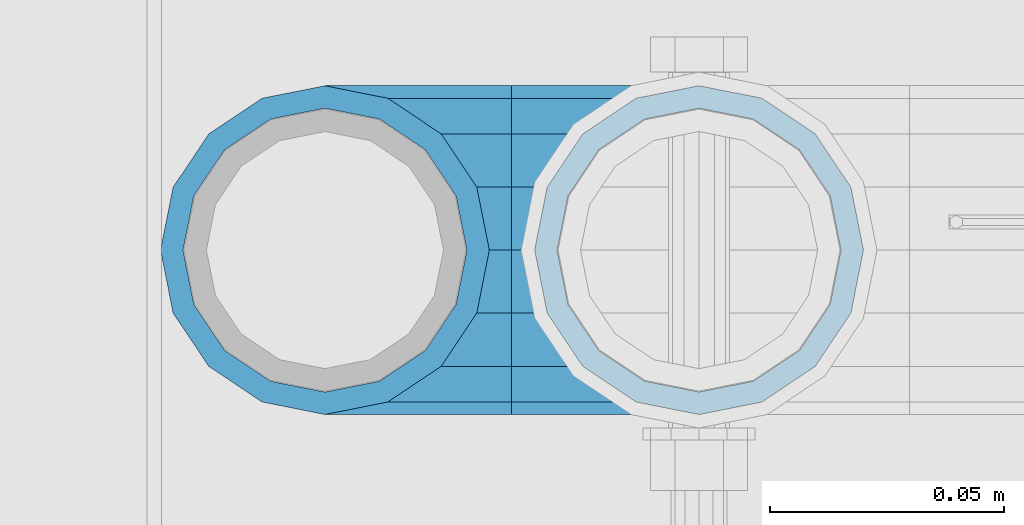
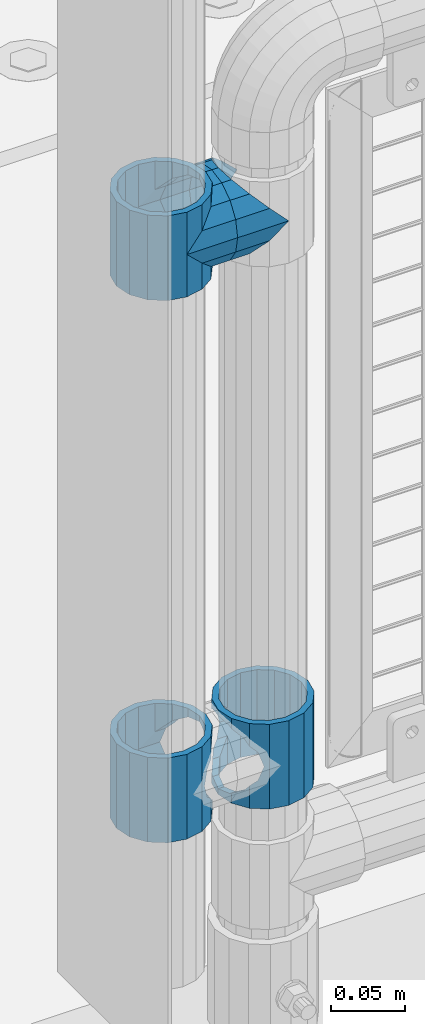
# One storey, part 146 of 257: 5 beams.
"""IFC2X3 building model written with IfcOpenShell, lengths in millimetres."""

import ifcopenshell
import ifcopenshell.guid

model = None  # the IFC model being written
_history = None  # IfcOwnerHistory: only IFC2X3 demands one
_inside = {}  # id of a spatial element -> (the spatial element, [elements in it])
_under = {}  # id of a project, library or spatial element -> (it, [spatial elements below it])
_declared = {}  # id of a project -> (the project, [libraries it declares])
_typed = {}  # id of a type object -> (the type object, [elements of that type])
_made_of = {}  # id of a material, layer set ... -> (it, [elements and type objects made of it])


def new_model(schema):
    """Start an empty IFC model of exactly this schema.

    Asked for "IFC4X3", IfcOpenShell would pick the latest addendum, in which some entities
    have other attributes; the version numbers below select the first issue.
    IFC2X3 requires an IfcOwnerHistory on every rooted entity: one is made here for all.
    """
    global model, _history
    if schema == "IFC4X3":
        model = ifcopenshell.file(schema_version=(4, 3, 0, 0))
    else:
        model = ifcopenshell.file(schema=schema)
    _inside.clear()
    _under.clear()
    _declared.clear()
    _typed.clear()
    _made_of.clear()
    _history = None
    if model.schema == "IFC2X3":
        org = make("IfcOrganization", Name="unknown")
        user = make(
            "IfcPersonAndOrganization",
            ThePerson=make("IfcPerson", FamilyName="unknown"),
            TheOrganization=org,
        )
        app = make(
            "IfcApplication",
            ApplicationDeveloper=org,
            Version="unknown",
            ApplicationFullName="unknown",
            ApplicationIdentifier="unknown",
        )
        _history = make(
            "IfcOwnerHistory",
            OwningUser=user,
            OwningApplication=app,
            ChangeAction="ADDED",
            CreationDate=0,
        )
    return model


def make(cls, **values):
    """One entity of the class cls with the attributes given. An attribute that is None is left unset."""
    return model.create_entity(
        cls, **{name: value for name, value in values.items() if value is not None}
    )


def rooted(cls, **values):
    """An entity with a GlobalId (a new one), such as an element, a storey or a relation."""
    return make(cls, GlobalId=ifcopenshell.guid.new(), OwnerHistory=_history, **values)


def si_unit(unit_type, name, prefix=None):
    """IfcSIUnit, for example si_unit("LENGTHUNIT", "METRE", prefix="MILLI")."""
    return make("IfcSIUnit", UnitType=unit_type, Prefix=prefix, Name=name)


def assignment(units):
    """IfcUnitAssignment: the units of a project."""
    return None if units is None else make("IfcUnitAssignment", Units=units)


def point(xyz):
    """IfcCartesianPoint."""
    return None if xyz is None else make("IfcCartesianPoint", Coordinates=xyz)


def direction(xyz):
    """IfcDirection."""
    return None if xyz is None else make("IfcDirection", DirectionRatios=xyz)


def frame(location, z_axis=None, x_axis=None):
    """IfcAxis2Placement3D, a coordinate frame: its origin and axes. An axis left out is left unset."""
    return make(
        "IfcAxis2Placement3D",
        Location=point(location),
        Axis=direction(z_axis),
        RefDirection=direction(x_axis),
    )


def origin_with_axes():
    """The frame at (0, 0, 0) with the z axis (0, 0, 1) and the x axis (1, 0, 0) written out."""
    return frame((0.0, 0.0, 0.0), z_axis=(0.0, 0.0, 1.0), x_axis=(1.0, 0.0, 0.0))


def place(relative_to, where):
    """IfcLocalPlacement: puts the frame where relative to a parent placement (None: the world)."""
    return make(
        "IfcLocalPlacement", PlacementRelTo=relative_to, RelativePlacement=where
    )


def context(
    kind, dimensions, precision=None, world=None, true_north=None, identifier=None
):
    """IfcGeometricRepresentationContext, for example the 3D "Model" context."""
    return make(
        "IfcGeometricRepresentationContext",
        ContextIdentifier=identifier,
        ContextType=kind,
        CoordinateSpaceDimension=dimensions,
        Precision=precision,
        WorldCoordinateSystem=world,
        TrueNorth=true_north,
    )


def subcontext(parent, identifier, kind, view, scale=None):
    """IfcGeometricRepresentationSubContext, for example "Body" below "Model"."""
    return make(
        "IfcGeometricRepresentationSubContext",
        ContextIdentifier=identifier,
        ContextType=kind,
        ParentContext=parent,
        TargetScale=scale,
        TargetView=view,
    )


def project(units=None, contexts=None):
    """IfcProject with its units and contexts."""
    return rooted(
        "IfcProject",
        Name="project",
        RepresentationContexts=contexts,
        UnitsInContext=assignment(units),
    )


def spatial(cls, under=None, at=None, **own):
    """A site, building, storey or space (cls), placed at a placement, below another one or the project."""
    s = rooted(cls, ObjectPlacement=at, **own)
    if under is not None:
        _under.setdefault(under.id(), (under, []))[1].append(s)
    return s


def faces_of(points, faces, orient=None, outer=None):
    """IfcFace entities. A face is a list of loops; a loop is a list of indices into points, from 0.

    orient and outer hold one flag for each loop. By default every Orientation is true, the
    first loop of a face is its IfcFaceOuterBound and the others are IfcFaceBound.
    """
    made = []
    for i, loops in enumerate(faces):
        bounds = []
        for j, loop in enumerate(loops):
            is_outer = j == 0 if outer is None else outer[i][j]
            bounds.append(
                make(
                    "IfcFaceOuterBound" if is_outer else "IfcFaceBound",
                    Bound=make("IfcPolyLoop", Polygon=[points[k] for k in loop]),
                    Orientation=True if orient is None else orient[i][j],
                )
            )
        made.append(make("IfcFace", Bounds=bounds))
    return made


def faceted_brep(points, faces, orient=None, outer=None, voids=None):
    """IfcFacetedBrep: a solid bounded by flat faces; with voids (closed shells), ...WithVoids."""
    shared = [point(p) for p in points]
    hull = make("IfcClosedShell", CfsFaces=faces_of(shared, faces, orient, outer))
    if voids is None:
        return make("IfcFacetedBrep", Outer=hull)
    return make(
        "IfcFacetedBrepWithVoids",
        Outer=hull,
        Voids=[
            make(cls, CfsFaces=faces_of(shared, fs, o, b)) for cls, fs, o, b in voids
        ],
    )


def shape(context_of_items, identifier, shape_type, items):
    """IfcShapeRepresentation: the items that make up one representation, for example the "Body"."""
    return make(
        "IfcShapeRepresentation",
        ContextOfItems=context_of_items,
        RepresentationIdentifier=identifier,
        RepresentationType=shape_type,
        Items=items,
    )


def material(Name=None, Category=None):
    """IfcMaterial."""
    return make("IfcMaterial", Name=Name, Category=Category)


def made_of(thing, what):
    """Note that an element or type object is made of a material, layer set ...; save() writes the relation."""
    if what is not None:
        _made_of.setdefault(what.id(), (what, []))[1].append(thing)
    return thing


def type_object(cls, material=None, **own):
    """A type object (cls), such as IfcWallType, which elements share."""
    return made_of(rooted(cls, **own), material)


def element(
    cls,
    number,
    at=None,
    inside=None,
    cuts=None,
    type_object=None,
    material=None,
    context=None,
    identifier="Body",
    shape_type=None,
    held_by="IfcProductDefinitionShape",
    body=None,
    shapes=None,
    **own,
):
    """One element of the class cls, such as IfcWall. Its Tag is "e" and its number.

    at: its placement. inside: the storey or other place that contains it. cuts: it is an
    opening in that element (IfcRelVoidsElement). A single representation is given by context,
    identifier, shape_type and body (its items); several are given by shapes. held_by: the class
    of the entity that holds the representations. save() writes the other relations.
    """
    e = rooted(cls, Tag="e%d" % number, ObjectPlacement=at, **own)
    if body is not None:
        shapes = [shape(context, identifier, shape_type, body)]
    if shapes is not None:
        e.Representation = make(held_by, Representations=shapes)
    if inside is not None:
        _inside.setdefault(inside.id(), (inside, []))[1].append(e)
    if cuts is not None:
        rooted(
            "IfcRelVoidsElement", RelatingBuildingElement=cuts, RelatedOpeningElement=e
        )
    if type_object is not None:
        _typed.setdefault(type_object.id(), (type_object, []))[1].append(e)
    return made_of(e, material)


def aggregate(whole, parts):
    """IfcRelAggregates: a whole, such as a stair, and the parts it consists of."""
    return rooted("IfcRelAggregates", RelatingObject=whole, RelatedObjects=parts)


def save(model, path):
    """Write the relations noted so far, then the file.

    IfcRelAggregates (storeys below a building ...), IfcRelContainedInSpatialStructure (elements
    in a storey), IfcRelDefinesByType, IfcRelAssociatesMaterial and IfcRelDeclares: one each for
    every whole, place, type object, material and project.
    """
    for whole, parts in _under.values():
        aggregate(whole, parts)
    for where, things in _inside.values():
        rooted(
            "IfcRelContainedInSpatialStructure",
            RelatedElements=things,
            RelatingStructure=where,
        )
    for kind, things in _typed.values():
        rooted("IfcRelDefinesByType", RelatedObjects=things, RelatingType=kind)
    for what, things in _made_of.values():
        rooted("IfcRelAssociatesMaterial", RelatedObjects=things, RelatingMaterial=what)
    for by, libraries in _declared.values():
        rooted("IfcRelDeclares", RelatingContext=by, RelatedDefinitions=libraries)
    model.write(path)


model = new_model("IFC2X3")

# Units and contexts
model_context = context("Model", 3, precision=1e-05, world=origin_with_axes())
body_context = subcontext(model_context, "Body", "Model", "MODEL_VIEW")
ifc_project = project(units=[si_unit("LENGTHUNIT", "METRE", prefix="MILLI"), si_unit("AREAUNIT", "SQUARE_METRE"), si_unit("VOLUMEUNIT", "CUBIC_METRE"), si_unit("MASSUNIT", "GRAM", prefix="KILO"), si_unit("TIMEUNIT", "SECOND"), si_unit("PLANEANGLEUNIT", "RADIAN"), si_unit("SOLIDANGLEUNIT", "STERADIAN"), si_unit("THERMODYNAMICTEMPERATUREUNIT", "DEGREE_CELSIUS"), si_unit("LUMINOUSINTENSITYUNIT", "LUMEN")], contexts=[model_context])

# Site, building, storey
site_placement = place(None, origin_with_axes())
site = spatial("IfcSite", under=ifc_project, at=site_placement, CompositionType="ELEMENT")
building_placement = place(site_placement, origin_with_axes())
building = spatial("IfcBuilding", under=site, at=building_placement, Name="Standard", CompositionType="ELEMENT")
storey_placement = place(building_placement, origin_with_axes())
storey = spatial("IfcBuildingStorey", under=building, at=storey_placement, Name="Undefined", CompositionType="ELEMENT", Elevation=0.0)

# Beams
ifc_material = material(Name="Misc_Undefined")
beam_type = type_object("IfcBeamType", PredefinedType="NOTDEFINED")
beam_1_placement = place(storey_placement, frame((42991.0, 10664.5, 433.819999999999), z_axis=(-1.0, 0.0, 0.0), x_axis=(0.0, 0.0, -1.0)))
element("IfcBeam", 1, at=beam_1_placement, inside=storey, type_object=beam_type, material=ifc_material, context=body_context, shape_type="Brep", body=[
    faceted_brep([(7.11025618828205, -11.6144421722802, -32.8397438117245), (7.11025618828205, -11.6144421722802, -28.0397438117143), (13.6893091909879, -21.4606908090118, -21.4606908090136), (13.6893091909879, -21.4606908090118, -27.1226768591077), (8.33762048232484, -13.4513226476338, -32.4743655677739), (23.5355578277191, -28.0397438117179, -11.6144421722784), (23.5355578277191, -28.0397438117179, -20.0882031229849), (18.7689575919987, -24.8548033587067, -24.8548033587067), (35.1500000000015, -30.35, 0.0), (35.1499999999996, -30.3500000000004, -16.6306603983685), (46.7644421722801, -28.0397438117179, -11.6144421722784), (46.7644421722801, -28.0397438117179, -20.0882031229849), (51.5310424080038, -24.8548033587067, -24.8548033587067), (56.6106908090114, -21.4606908090118, -21.4606908090136), (56.6106908090114, -21.4606908090118, -27.1226768591077), (61.9623795176756, -13.4513226476338, -32.4743655677739), (63.1897438117172, -11.6144421722802, -28.0397438117143), (63.1897438117172, -11.6144421722802, -32.8397438117245), (65.4999999999997, 0.0, -30.3499999999985), (65.4999999999997, 0.0, -35.1500000000015), (63.1897438117172, 11.6144421722802, -28.0397438117143), (63.1897438117172, 11.6144421722802, -32.8397438117245), (56.6106908090114, 21.4606908090118, -21.4606908090136), (56.6106908090114, 21.4606908090118, -27.1226768591077), (61.9623795176756, 13.4513226476338, -32.4743655677739), (46.7644421722801, 28.0397438117179, -11.6144421722784), (46.7644421722801, 28.0397438117179, -20.0882031229921), (51.5310424080039, 24.8548033587067, -24.8548033587067), (35.1500000000015, 30.35, 0.0), (35.1499999999996, 30.3500000000004, -16.6306603983758), (23.5355578277192, 28.0397438117179, -11.6144421722784), (23.5355578277192, 28.0397438117179, -20.0882031229921), (18.7689575919954, 24.8548033587067, -24.8548033587067), (13.6893091909879, 21.4606908090118, -21.4606908090136), (13.6893091909879, 21.4606908090118, -27.1226768591077), (8.3376204823237, 13.4513226476338, -32.4743655677739), (7.11025618828211, 11.6144421722802, -28.0397438117143), (7.11025618828211, 11.6144421722802, -32.8397438117245), (4.79999999999961, 0.0, -30.3499999999985), (4.79999999999961, 0.0, -35.1500000000015), (0.0, 21.4606908090118, 21.4606908090136), (0.0, 28.0397438117179, 11.6144421722784), (70.2999999999993, 28.0397438117179, 11.6144421722784), (70.2999999999993, 21.4606908090118, 21.4606908090136), (0.0, 11.6144421722802, 28.0397438117143), (70.2999999999993, 11.6144421722802, 28.0397438117143), (0.0, 0.0, 30.3499999999985), (70.2999999999993, 0.0, 30.3499999999985), (0.0, -11.6144421722802, 28.0397438117143), (70.2999999999993, -11.6144421722802, 28.0397438117143), (0.0, -21.4606908090118, 21.4606908090136), (70.2999999999993, -21.4606908090118, 21.4606908090136), (0.0, -28.0397438117179, 11.6144421722784), (70.2999999999993, -28.0397438117179, 11.6144421722784), (0.0, -24.8548033587067, -24.8548033587067), (0.0, -13.4513226476338, -32.4743655677739), (0.0, 0.0, -35.1499999999996), (0.0, -32.4743655677721, 13.4513226476338), (0.0, -35.1499999999996, 0.0), (70.2999999999993, -35.1499999999996, 0.0), (70.2999999999993, -32.4743655677721, 13.4513226476338), (0.0, -24.8548033587067, 24.8548033587067), (70.2999999999993, -24.8548033587067, 24.8548033587067), (0.0, -13.4513226476338, 32.4743655677739), (70.2999999999993, -13.4513226476338, 32.4743655677739), (0.0, 0.0, 35.1499999999996), (70.2999999999993, 0.0, 35.1500000000015), (0.0, 13.4513226476338, 32.4743655677739), (70.2999999999993, 13.4513226476338, 32.4743655677739), (0.0, 24.8548033587067, 24.8548033587067), (70.2999999999993, 24.8548033587067, 24.8548033587067), (0.0, 32.4743655677721, 13.4513226476338), (70.2999999999993, 32.4743655677721, 13.4513226476338), (0.0, 35.1499999999996, 0.0), (70.2999999999993, 35.1499999999996, 0.0), (0.0, 32.4743655677721, -13.4513226476338), (70.2999999999993, 32.4743655677721, -13.4513226476338), (70.2999999999993, -13.4513226476338, -32.4743655677739), (70.2999999999993, -24.8548033587067, -24.8548033587067), (70.2999999999993, 0.0, -35.1500000000015), (70.2999999999993, 13.4513226476338, -32.4743655677739), (70.2999999999993, 24.8548033587067, -24.8548033587067), (0.0, 24.8548033587067, -24.8548033587067), (0.0, 13.4513226476338, -32.4743655677739), (70.2999999999993, -32.4743655677721, -13.4513226476338), (0.0, -32.4743655677721, -13.4513226476338), (0.0, -28.0397438117179, -11.6144421722784), (0.0, -21.4606908090118, -21.4606908090136), (0.0, -11.6144421722802, -28.0397438117143), (0.0, 0.0, -30.3499999999985), (0.0, 11.6144421722802, -28.0397438117143), (0.0, 21.4606908090118, -21.4606908090136), (0.0, 28.0397438117179, -11.6144421722784), (0.0, 30.3500000000004, 0.0), (0.0, -30.3500000000004, 0.0), (70.2999999999993, 30.3500000000004, 0.0), (70.2999999999993, 28.0397438117179, -11.6144421722784), (70.2999999999993, 21.4606908090118, -21.4606908090136), (70.2999999999993, 11.6144421722802, -28.0397438117143), (70.2999999999993, 0.0, -30.3499999999985), (70.2999999999993, -11.6144421722802, -28.0397438117143), (70.2999999999993, -21.4606908090118, -21.4606908090136), (70.2999999999993, -28.0397438117179, -11.6144421722784), (70.2999999999993, -30.3500000000004, 0.0)], [[[0, 1, 2, 3, 4]], [[3, 2, 5, 6, 7]], [[6, 5, 8, 9]], [[9, 8, 10, 11]], [[12, 11, 10, 13, 14]], [[15, 14, 13, 16, 17]], [[17, 16, 18, 19]], [[19, 18, 20, 21]], [[21, 20, 22, 23, 24]], [[23, 22, 25, 26, 27]], [[26, 25, 28, 29]], [[29, 28, 30, 31]], [[32, 31, 30, 33, 34]], [[35, 34, 33, 36, 37]], [[37, 36, 38, 39]], [[39, 38, 1, 0]], [[40, 41, 42, 43]], [[44, 40, 43, 45]], [[46, 44, 45, 47]], [[48, 46, 47, 49]], [[50, 48, 49, 51]], [[52, 50, 51, 53]], [[7, 54, 55, 4, 3]], [[4, 55, 56, 39, 0]], [[57, 58, 59, 60]], [[61, 57, 60, 62]], [[63, 61, 62, 64]], [[65, 63, 64, 66]], [[67, 65, 66, 68]], [[69, 67, 68, 70]], [[71, 69, 70, 72]], [[73, 71, 72, 74]], [[75, 73, 74, 76]], [[77, 78, 12, 14, 15]], [[79, 77, 15, 17, 19]], [[24, 80, 79, 19, 21]], [[27, 81, 80, 24, 23]], [[29, 31, 32, 82, 75, 76, 81, 27, 26]], [[83, 82, 32, 34, 35]], [[56, 83, 35, 37, 39]], [[78, 84, 85, 54, 7, 6, 9, 11, 12]], [[58, 85, 84, 59]], [[57, 61, 63, 65, 67, 69, 71, 73, 75, 82, 83, 56, 55, 54, 85, 58], [86, 87, 88, 89, 90, 91, 92, 93, 41, 40, 44, 46, 48, 50, 52, 94]], [[90, 89, 38, 36]], [[91, 90, 36, 33]], [[92, 91, 33, 30]], [[93, 92, 30, 28]], [[41, 93, 28, 95, 42]], [[96, 95, 28, 25]], [[97, 96, 25, 22]], [[98, 97, 22, 20]], [[99, 98, 20, 18]], [[100, 99, 18, 16]], [[101, 100, 16, 13]], [[102, 101, 13, 10]], [[103, 102, 10, 8]], [[78, 77, 79, 80, 81, 76, 74, 72, 70, 68, 66, 64, 62, 60, 59, 84], [51, 49, 47, 45, 43, 42, 95, 96, 97, 98, 99, 100, 101, 102, 103, 53]], [[8, 94, 52, 53, 103]], [[86, 94, 8, 5]], [[87, 86, 5, 2]], [[88, 87, 2, 1]], [[89, 88, 1, 38]]]),
])
beam_2_placement = place(storey_placement, frame((43071.0, 10664.5, 433.819999999999), z_axis=(1.0, 0.0, 0.0), x_axis=(0.0, 0.0, -1.0)))
element("IfcBeam", 2, at=beam_2_placement, inside=storey, type_object=beam_type, material=ifc_material, context=body_context, shape_type="Brep", body=[
    faceted_brep([(56.6106908090114, 21.4606908090118, -27.1226768591077), (56.6106908090114, 21.4606908090118, -21.4606908090136), (46.7644421722801, 28.0397438117179, -11.6144421722784), (46.7644421722801, 28.0397438117179, -20.0882031229921), (51.5310424080039, 24.8548033587067, -24.8548033587067), (63.1897438117172, 11.6144421722802, -32.8397438117245), (63.1897438117172, 11.6144421722802, -28.0397438117143), (61.9623795176756, 13.4513226476338, -32.4743655677739), (65.4999999999997, 0.0, -35.1500000000015), (65.4999999999997, 0.0, -30.3499999999985), (63.1897438117172, -11.6144421722802, -32.8397438117245), (63.1897438117172, -11.6144421722802, -28.0397438117143), (61.9623795176756, -13.4513226476338, -32.4743655677739), (56.6106908090114, -21.4606908090118, -27.1226768591077), (56.6106908090114, -21.4606908090118, -21.4606908090136), (51.5310424080038, -24.8548033587067, -24.8548033587067), (46.7644421722801, -28.0397438117179, -20.0882031229849), (46.7644421722801, -28.0397438117179, -11.6144421722784), (35.1499999999996, -30.3500000000004, -16.6306603983685), (35.1500000000015, -30.35, 0.0), (23.5355578277191, -28.0397438117179, -20.0882031229849), (23.5355578277191, -28.0397438117179, -11.6144421722784), (13.6893091909879, -21.4606908090118, -27.1226768591077), (13.6893091909879, -21.4606908090118, -21.4606908090136), (18.7689575919987, -24.8548033587067, -24.8548033587067), (7.11025618828205, -11.6144421722802, -32.8397438117245), (7.11025618828205, -11.6144421722802, -28.0397438117143), (8.33762048232484, -13.4513226476338, -32.4743655677739), (4.79999999999961, 0.0, -35.1500000000015), (4.79999999999961, 0.0, -30.3499999999985), (7.11025618828211, 11.6144421722802, -32.8397438117245), (7.11025618828211, 11.6144421722802, -28.0397438117143), (8.3376204823237, 13.4513226476338, -32.4743655677739), (13.6893091909879, 21.4606908090118, -27.1226768591077), (13.6893091909879, 21.4606908090118, -21.4606908090136), (18.7689575919954, 24.8548033587067, -24.8548033587067), (23.5355578277192, 28.0397438117179, -20.0882031229921), (23.5355578277192, 28.0397438117179, -11.6144421722784), (35.1499999999996, 30.3500000000004, -16.6306603983758), (35.1500000000015, 30.35, 0.0), (0.0, 32.4743655677721, -13.4513226476338), (0.0, 35.1499999999996, 0.0), (70.2999999999993, 35.1499999999996, 0.0), (70.2999999999993, 32.4743655677721, -13.4513226476338), (0.0, 32.4743655677721, 13.4513226476338), (70.2999999999993, 32.4743655677721, 13.4513226476338), (0.0, 24.8548033587067, 24.8548033587067), (70.2999999999993, 24.8548033587067, 24.8548033587067), (0.0, 13.4513226476338, 32.4743655677739), (70.2999999999993, 13.4513226476338, 32.4743655677739), (0.0, 0.0, 35.1499999999996), (70.2999999999993, 0.0, 35.1500000000015), (0.0, -13.4513226476338, 32.4743655677739), (70.2999999999993, -13.4513226476338, 32.4743655677739), (0.0, -24.8548033587067, 24.8548033587067), (70.2999999999993, -24.8548033587067, 24.8548033587067), (0.0, -32.4743655677721, 13.4513226476338), (70.2999999999993, -32.4743655677721, 13.4513226476338), (0.0, -35.1499999999996, 0.0), (70.2999999999993, -35.1499999999996, 0.0), (70.2999999999993, -30.3500000000004, 0.0), (70.2999999999993, -28.0397438117179, -11.6144421722784), (70.2999999999993, -21.4606908090118, -21.4606908090136), (70.2999999999993, -11.6144421722802, -28.0397438117143), (70.2999999999993, 0.0, -30.3499999999985), (70.2999999999993, 11.6144421722802, -28.0397438117143), (70.2999999999993, 21.4606908090118, -21.4606908090136), (70.2999999999993, 28.0397438117179, -11.6144421722784), (0.0, -28.0397438117179, -11.6144421722784), (0.0, -30.3500000000004, 0.0), (0.0, -21.4606908090118, -21.4606908090136), (0.0, -11.6144421722802, -28.0397438117143), (0.0, 0.0, -30.3499999999985), (0.0, 11.6144421722802, -28.0397438117143), (0.0, 21.4606908090118, -21.4606908090136), (0.0, 28.0397438117179, -11.6144421722784), (0.0, 30.3500000000004, 0.0), (70.2999999999993, 30.3500000000004, 0.0), (0.0, 28.0397438117179, 11.6144421722784), (70.2999999999993, 28.0397438117179, 11.6144421722784), (0.0, 21.4606908090118, 21.4606908090136), (70.2999999999993, 21.4606908090118, 21.4606908090136), (0.0, 11.6144421722802, 28.0397438117143), (70.2999999999993, 11.6144421722802, 28.0397438117143), (0.0, 0.0, 30.3499999999985), (70.2999999999993, 0.0, 30.3499999999985), (0.0, -11.6144421722802, 28.0397438117143), (70.2999999999993, -11.6144421722802, 28.0397438117143), (0.0, -21.4606908090118, 21.4606908090136), (70.2999999999993, -21.4606908090118, 21.4606908090136), (0.0, -28.0397438117179, 11.6144421722784), (70.2999999999993, -28.0397438117179, 11.6144421722784), (70.2999999999993, -24.8548033587067, -24.8548033587067), (70.2999999999993, -13.4513226476338, -32.4743655677739), (70.2999999999993, 0.0, -35.1500000000015), (70.2999999999993, 13.4513226476338, -32.4743655677739), (70.2999999999993, 24.8548033587067, -24.8548033587067), (70.2999999999993, -32.4743655677721, -13.4513226476338), (0.0, -32.4743655677721, -13.4513226476338), (0.0, 24.8548033587067, -24.8548033587067), (0.0, 13.4513226476338, -32.4743655677739), (0.0, 0.0, -35.1499999999996), (0.0, -13.4513226476338, -32.4743655677739), (0.0, -24.8548033587067, -24.8548033587067)], [[[0, 1, 2, 3, 4]], [[5, 6, 1, 0, 7]], [[8, 9, 6, 5]], [[10, 11, 9, 8]], [[12, 13, 14, 11, 10]], [[15, 16, 17, 14, 13]], [[18, 19, 17, 16]], [[20, 21, 19, 18]], [[22, 23, 21, 20, 24]], [[25, 26, 23, 22, 27]], [[28, 29, 26, 25]], [[30, 31, 29, 28]], [[32, 33, 34, 31, 30]], [[35, 36, 37, 34, 33]], [[38, 39, 37, 36]], [[3, 2, 39, 38]], [[40, 41, 42, 43]], [[41, 44, 45, 42]], [[44, 46, 47, 45]], [[46, 48, 49, 47]], [[48, 50, 51, 49]], [[50, 52, 53, 51]], [[52, 54, 55, 53]], [[54, 56, 57, 55]], [[56, 58, 59, 57]], [[60, 61, 17, 19]], [[61, 62, 14, 17]], [[62, 63, 11, 14]], [[63, 64, 9, 11]], [[64, 65, 6, 9]], [[65, 66, 1, 6]], [[66, 67, 2, 1]], [[68, 69, 19, 21]], [[70, 68, 21, 23]], [[71, 70, 23, 26]], [[72, 71, 26, 29]], [[73, 72, 29, 31]], [[74, 73, 31, 34]], [[75, 74, 34, 37]], [[76, 75, 37, 39]], [[67, 77, 39, 2]], [[78, 76, 39, 77, 79]], [[80, 78, 79, 81]], [[82, 80, 81, 83]], [[84, 82, 83, 85]], [[86, 84, 85, 87]], [[88, 86, 87, 89]], [[90, 88, 89, 91]], [[19, 69, 90, 91, 60]], [[92, 93, 94, 95, 96, 43, 42, 45, 47, 49, 51, 53, 55, 57, 59, 97], [89, 87, 85, 83, 81, 79, 77, 67, 66, 65, 64, 63, 62, 61, 60, 91]], [[58, 98, 97, 59]], [[56, 54, 52, 50, 48, 46, 44, 41, 40, 99, 100, 101, 102, 103, 98, 58], [68, 70, 71, 72, 73, 74, 75, 76, 78, 80, 82, 84, 86, 88, 90, 69]], [[100, 99, 35, 33, 32]], [[101, 100, 32, 30, 28]], [[27, 102, 101, 28, 25]], [[24, 103, 102, 27, 22]], [[92, 97, 98, 103, 24, 20, 18, 16, 15]], [[93, 92, 15, 13, 12]], [[94, 93, 12, 10, 8]], [[7, 95, 94, 8, 5]], [[4, 96, 95, 7, 0]], [[38, 36, 35, 99, 40, 43, 96, 4, 3]]]),
])
beam_3_placement = place(storey_placement, frame((42991.0, 10664.5, 848.669999999999), z_axis=(0.0, -1.0, 0.0), x_axis=(1.0, 0.0, 0.0)))
element("IfcBeam", 3, at=beam_3_placement, inside=storey, type_object=beam_type, material=ifc_material, context=body_context, shape_type="Brep", body=[
    faceted_brep([(13.4513226476338, -13.4513226476329, -32.4743655677721), (13.4513226476338, 13.4513226476329, -32.4743655677721), (0.0, 0.0, -35.1499999999996), (27.122676859115, 21.4606908090117, 21.4606908090118), (24.8548033587067, 16.3810424080013, 24.8548033587067), (24.8548033587067, 24.8548033587072, 24.8548033587067), (32.4743655677739, 32.4743655677717, 13.4513226476338), (32.4743655677739, 26.8123795176755, 13.4513226476338), (0.0, 0.0, 35.1499999999996), (13.4513226476338, 13.4513226476329, 32.4743655677721), (13.4513226476338, -13.4513226476329, 32.4743655677721), (20.0882031229849, 11.6144421722805, 28.0397438117179), (16.6306603983758, 0.0, 30.3500000000004), (20.0882031229849, -11.6144421722805, 28.0397438117179), (24.8548033587067, -16.3810424080013, 24.8548033587067), (24.8548033587067, -24.8548033587072, 24.8548033587067), (27.122676859115, -21.4606908090117, 21.4606908090118), (32.4743655677739, -26.8123795176754, 13.4513226476338), (32.4743655677739, -32.4743655677717, 13.4513226476338), (32.8397438117172, -28.0397438117175, 11.6144421722802), (35.1500000000015, -30.35, 0.0), (35.1500000000015, -35.1499999999996, 0.0), (32.8397438117172, -28.0397438117175, -11.6144421722802), (32.4743655677739, -26.8123795176755, -13.4513226476338), (32.4743655677739, -32.4743655677717, -13.4513226476338), (27.1226768591005, -21.4606908090117, -21.4606908090118), (24.8548033587067, -16.3810424080045, -24.8548033587067), (24.8548033587067, -24.8548033587072, -24.8548033587067), (20.0882031229849, -11.6144421722805, -28.0397438117179), (16.6306603983685, 0.0, -30.3500000000004), (20.0882031229849, 11.6144421722805, -28.0397438117179), (24.8548033587067, 16.3810424080013, -24.8548033587067), (24.8548033587067, 24.8548033587072, -24.8548033587067), (32.4743655677739, 26.8123795176754, -13.4513226476338), (32.4743655677739, 32.4743655677717, -13.4513226476338), (27.1226768591005, 21.4606908090117, -21.4606908090118), (35.1500000000015, 30.35, 0.0), (35.1500000000015, 35.15, 0.0), (32.8397438117172, 28.0397438117175, -11.6144421722802), (32.8397438117172, 28.0397438117175, 11.6144421722802), (40.1500000000015, -35.15, 0.0), (40.1500000000015, -32.4743655677717, 13.4513226476338), (40.1500000000015, -24.8548033587072, 24.8548033587067), (40.1500000000015, -13.4513226476329, 32.4743655677721), (40.1500000000015, 0.0, 35.1499999999996), (40.1500000000015, 13.4513226476329, 32.4743655677721), (40.1500000000015, 24.8548033587072, 24.8548033587067), (40.1500000000015, 32.4743655677717, 13.4513226476338), (40.1500000000015, 35.15, 0.0), (40.1500000000015, -24.8548033587072, -24.8548033587067), (40.1500000000015, -32.4743655677717, -13.4513226476338), (40.1500000000015, -13.4513226476329, -32.4743655677721), (40.1500000000015, 0.0, -35.1499999999996), (40.1500000000015, 13.4513226476329, -32.4743655677721), (40.1500000000015, 24.8548033587072, -24.8548033587067), (40.1500000000015, 32.4743655677717, -13.4513226476338), (40.1500000000015, -21.4606908090117, 21.4606908090118), (40.1500000000015, -11.6144421722805, 28.0397438117179), (40.1500000000015, 0.0, 30.3500000000004), (40.1500000000015, 11.6144421722805, 28.0397438117179), (40.1500000000015, 21.4606908090117, 21.4606908090118), (40.1500000000015, 28.0397438117175, 11.6144421722802), (40.1500000000015, 30.35, 0.0), (40.1500000000015, 28.0397438117175, -11.6144421722802), (40.1500000000015, 21.4606908090117, -21.4606908090118), (40.1500000000015, 11.6144421722805, -28.0397438117179), (40.1500000000015, 0.0, -30.3500000000004), (40.1500000000015, -11.6144421722805, -28.0397438117179), (40.1500000000015, -21.4606908090117, -21.4606908090118), (40.1500000000015, -28.0397438117175, -11.6144421722802), (40.1500000000015, -30.35, 0.0), (40.1500000000015, -28.0397438117175, 11.6144421722802)], [[[0, 1, 2]], [[3, 4, 5, 6, 7]], [[8, 9, 10]], [[10, 9, 5, 4, 11, 12, 13, 14, 15]], [[15, 14, 16, 17, 18]], [[18, 17, 19, 20, 21]], [[21, 20, 22, 23, 24]], [[24, 23, 25, 26, 27]], [[27, 26, 28, 29, 30, 31, 32, 1, 0]], [[33, 34, 32, 31, 35]], [[36, 37, 34, 33, 38]], [[39, 7, 6, 37, 36]], [[40, 41, 18, 21]], [[41, 42, 15, 18]], [[42, 43, 10, 15]], [[43, 44, 8, 10]], [[44, 45, 9, 8]], [[45, 46, 5, 9]], [[46, 47, 6, 5]], [[47, 48, 37, 6]], [[49, 50, 24, 27]], [[51, 49, 27, 0]], [[52, 51, 0, 2]], [[53, 52, 2, 1]], [[54, 53, 1, 32]], [[55, 54, 32, 34]], [[48, 55, 34, 37]], [[50, 40, 21, 24]], [[49, 51, 52, 53, 54, 55, 48, 47, 46, 45, 44, 43, 42, 41, 40, 50], [56, 57, 58, 59, 60, 61, 62, 63, 64, 65, 66, 67, 68, 69, 70, 71]], [[63, 62, 36, 38]], [[35, 64, 63, 38, 33]], [[30, 65, 64, 35, 31]], [[66, 65, 30, 29]], [[67, 66, 29, 28]], [[68, 67, 28, 26, 25]], [[69, 68, 25, 23, 22]], [[70, 69, 22, 20]], [[71, 70, 20, 19]], [[16, 56, 71, 19, 17]], [[13, 57, 56, 16, 14]], [[58, 57, 13, 12]], [[59, 58, 12, 11]], [[60, 59, 11, 4, 3]], [[61, 60, 3, 7, 39]], [[62, 61, 39, 36]]]),
])
beam_4_placement = place(storey_placement, frame((43071.0, 10664.5, 848.669999999999), z_axis=(0.0, 1.0, 0.0), x_axis=(-1.0, 0.0, 0.0)))
element("IfcBeam", 4, at=beam_4_placement, inside=storey, type_object=beam_type, material=ifc_material, context=body_context, shape_type="Brep", body=[
    faceted_brep([(13.4513226476338, -13.4513226476329, -32.4743655677721), (13.4513226476338, 13.4513226476329, -32.4743655677721), (0.0, 0.0, -35.1499999999996), (24.8548033587067, -24.8548033587072, 24.8548033587067), (24.8548033587067, -16.3810424080013, 24.8548033587067), (27.122676859115, -21.4606908090117, 21.4606908090118), (32.4743655677739, -26.8123795176754, 13.4513226476338), (32.4743655677739, -32.4743655677717, 13.4513226476338), (32.8397438117172, -28.0397438117175, 11.6144421722802), (35.1500000000015, -30.35, 0.0), (35.1500000000015, -35.1499999999996, 0.0), (32.8397438117172, -28.0397438117175, -11.6144421722802), (32.4743655677739, -26.8123795176755, -13.4513226476338), (32.4743655677739, -32.4743655677717, -13.4513226476338), (27.1226768591005, -21.4606908090117, -21.4606908090118), (24.8548033587067, -16.3810424080045, -24.8548033587067), (24.8548033587067, -24.8548033587072, -24.8548033587067), (20.0882031229849, -11.6144421722805, -28.0397438117179), (16.6306603983685, 0.0, -30.3500000000004), (20.0882031229849, 11.6144421722805, -28.0397438117179), (24.8548033587067, 16.3810424080013, -24.8548033587067), (24.8548033587067, 24.8548033587072, -24.8548033587067), (32.4743655677739, 26.8123795176754, -13.4513226476338), (32.4743655677739, 32.4743655677717, -13.4513226476338), (27.1226768591005, 21.4606908090117, -21.4606908090118), (35.1500000000015, 30.35, 0.0), (35.1500000000015, 35.15, 0.0), (32.8397438117172, 28.0397438117175, -11.6144421722802), (32.8397438117172, 28.0397438117175, 11.6144421722802), (32.4743655677739, 26.8123795176755, 13.4513226476338), (32.4743655677739, 32.4743655677717, 13.4513226476338), (27.122676859115, 21.4606908090117, 21.4606908090118), (24.8548033587067, 16.3810424080013, 24.8548033587067), (24.8548033587067, 24.8548033587072, 24.8548033587067), (0.0, 0.0, 35.1499999999996), (13.4513226476338, 13.4513226476329, 32.4743655677721), (13.4513226476338, -13.4513226476329, 32.4743655677721), (20.0882031229849, 11.6144421722805, 28.0397438117179), (16.6306603983758, 0.0, 30.3500000000004), (20.0882031229849, -11.6144421722805, 28.0397438117179), (40.1500000000015, -35.15, 0.0), (40.1500000000015, -32.4743655677717, 13.4513226476338), (40.1500000000015, -24.8548033587072, 24.8548033587067), (40.1500000000015, -13.4513226476329, 32.4743655677721), (40.1500000000015, 0.0, 35.1499999999996), (40.1500000000015, -24.8548033587072, -24.8548033587067), (40.1500000000015, -32.4743655677717, -13.4513226476338), (40.1500000000015, -13.4513226476329, -32.4743655677721), (40.1500000000015, 0.0, -35.1499999999996), (40.1500000000015, 13.4513226476329, -32.4743655677721), (40.1500000000015, 24.8548033587072, -24.8548033587067), (40.1500000000015, 32.4743655677717, -13.4513226476338), (40.1500000000015, 35.15, 0.0), (40.1500000000015, 32.4743655677717, 13.4513226476338), (40.1500000000015, 24.8548033587072, 24.8548033587067), (40.1500000000015, 13.4513226476329, 32.4743655677721), (40.1500000000015, -21.4606908090117, 21.4606908090118), (40.1500000000015, -11.6144421722805, 28.0397438117179), (40.1500000000015, 0.0, 30.3500000000004), (40.1500000000015, 11.6144421722805, 28.0397438117179), (40.1500000000015, 21.4606908090117, 21.4606908090118), (40.1500000000015, 28.0397438117175, 11.6144421722802), (40.1500000000015, 30.35, 0.0), (40.1500000000015, 28.0397438117175, -11.6144421722802), (40.1500000000015, 21.4606908090117, -21.4606908090118), (40.1500000000015, 11.6144421722805, -28.0397438117179), (40.1500000000015, 0.0, -30.3500000000004), (40.1500000000015, -11.6144421722805, -28.0397438117179), (40.1500000000015, -21.4606908090117, -21.4606908090118), (40.1500000000015, -28.0397438117175, -11.6144421722802), (40.1500000000015, -30.35, 0.0), (40.1500000000015, -28.0397438117175, 11.6144421722802)], [[[0, 1, 2]], [[3, 4, 5, 6, 7]], [[7, 6, 8, 9, 10]], [[10, 9, 11, 12, 13]], [[13, 12, 14, 15, 16]], [[16, 15, 17, 18, 19, 20, 21, 1, 0]], [[22, 23, 21, 20, 24]], [[25, 26, 23, 22, 27]], [[28, 29, 30, 26, 25]], [[31, 32, 33, 30, 29]], [[34, 35, 36]], [[36, 35, 33, 32, 37, 38, 39, 4, 3]], [[40, 41, 7, 10]], [[41, 42, 3, 7]], [[42, 43, 36, 3]], [[43, 44, 34, 36]], [[45, 46, 13, 16]], [[47, 45, 16, 0]], [[48, 47, 0, 2]], [[49, 48, 2, 1]], [[50, 49, 1, 21]], [[51, 50, 21, 23]], [[52, 51, 23, 26]], [[53, 52, 26, 30]], [[54, 53, 30, 33]], [[55, 54, 33, 35]], [[44, 55, 35, 34]], [[46, 40, 10, 13]], [[45, 47, 48, 49, 50, 51, 52, 53, 54, 55, 44, 43, 42, 41, 40, 46], [56, 57, 58, 59, 60, 61, 62, 63, 64, 65, 66, 67, 68, 69, 70, 71]], [[59, 58, 38, 37]], [[60, 59, 37, 32, 31]], [[61, 60, 31, 29, 28]], [[62, 61, 28, 25]], [[63, 62, 25, 27]], [[24, 64, 63, 27, 22]], [[19, 65, 64, 24, 20]], [[66, 65, 19, 18]], [[67, 66, 18, 17]], [[68, 67, 17, 15, 14]], [[69, 68, 14, 12, 11]], [[70, 69, 11, 9]], [[71, 70, 9, 8]], [[5, 56, 71, 8, 6]], [[39, 57, 56, 5, 4]], [[58, 57, 39, 38]]]),
])
beam_5_placement = place(storey_placement, frame((42991.0, 10664.5, 883.819999999999), z_axis=(-1.0, 0.0, 0.0), x_axis=(0.0, 0.0, -1.0)))
element("IfcBeam", 5, at=beam_5_placement, inside=storey, type_object=beam_type, material=ifc_material, context=body_context, shape_type="Brep", body=[
    faceted_brep([(7.11025618828205, -11.6144421722802, -32.8397438117245), (7.11025618828205, -11.6144421722802, -28.0397438117143), (13.6893091909879, -21.4606908090118, -21.4606908090136), (13.6893091909879, -21.4606908090118, -27.1226768591077), (8.33762048232484, -13.4513226476338, -32.4743655677739), (23.5355578277191, -28.0397438117179, -11.6144421722784), (23.5355578277191, -28.0397438117179, -20.0882031229849), (18.7689575919987, -24.8548033587067, -24.8548033587067), (35.1500000000015, -30.35, 0.0), (35.1499999999996, -30.3500000000004, -16.6306603983685), (46.7644421722801, -28.0397438117179, -11.6144421722784), (46.7644421722801, -28.0397438117179, -20.0882031229849), (51.5310424080038, -24.8548033587067, -24.8548033587067), (56.6106908090114, -21.4606908090118, -21.4606908090136), (56.6106908090114, -21.4606908090118, -27.1226768591077), (61.9623795176756, -13.4513226476338, -32.4743655677739), (63.1897438117172, -11.6144421722802, -28.0397438117143), (63.1897438117172, -11.6144421722802, -32.8397438117245), (65.4999999999997, 0.0, -30.3499999999985), (65.4999999999997, 0.0, -35.1500000000015), (63.1897438117172, 11.6144421722802, -28.0397438117143), (63.1897438117172, 11.6144421722802, -32.8397438117245), (56.6106908090114, 21.4606908090118, -21.4606908090136), (56.6106908090114, 21.4606908090118, -27.1226768591077), (61.9623795176756, 13.4513226476338, -32.4743655677739), (46.7644421722801, 28.0397438117179, -11.6144421722784), (46.7644421722801, 28.0397438117179, -20.0882031229921), (51.5310424080039, 24.8548033587067, -24.8548033587067), (35.1500000000015, 30.35, 0.0), (35.1499999999996, 30.3500000000004, -16.6306603983758), (23.5355578277192, 28.0397438117179, -11.6144421722784), (23.5355578277192, 28.0397438117179, -20.0882031229921), (18.7689575919954, 24.8548033587067, -24.8548033587067), (13.6893091909879, 21.4606908090118, -21.4606908090136), (13.6893091909879, 21.4606908090118, -27.1226768591077), (8.3376204823237, 13.4513226476338, -32.4743655677739), (7.11025618828211, 11.6144421722802, -28.0397438117143), (7.11025618828211, 11.6144421722802, -32.8397438117245), (4.79999999999961, 0.0, -30.3499999999985), (4.79999999999961, 0.0, -35.1500000000015), (0.0, 21.4606908090118, 21.4606908090136), (0.0, 28.0397438117179, 11.6144421722784), (70.2999999999993, 28.0397438117179, 11.6144421722784), (70.2999999999993, 21.4606908090118, 21.4606908090136), (0.0, 11.6144421722802, 28.0397438117143), (70.2999999999993, 11.6144421722802, 28.0397438117143), (0.0, 0.0, 30.3499999999985), (70.2999999999993, 0.0, 30.3499999999985), (0.0, -11.6144421722802, 28.0397438117143), (70.2999999999993, -11.6144421722802, 28.0397438117143), (0.0, -21.4606908090118, 21.4606908090136), (70.2999999999993, -21.4606908090118, 21.4606908090136), (0.0, -28.0397438117179, 11.6144421722784), (70.2999999999993, -28.0397438117179, 11.6144421722784), (0.0, -24.8548033587067, -24.8548033587067), (0.0, -13.4513226476338, -32.4743655677739), (0.0, 0.0, -35.1499999999996), (0.0, -32.4743655677721, 13.4513226476338), (0.0, -35.1499999999996, 0.0), (70.2999999999993, -35.1499999999996, 0.0), (70.2999999999993, -32.4743655677721, 13.4513226476338), (0.0, -24.8548033587067, 24.8548033587067), (70.2999999999993, -24.8548033587067, 24.8548033587067), (0.0, -13.4513226476338, 32.4743655677739), (70.2999999999993, -13.4513226476338, 32.4743655677739), (0.0, 0.0, 35.1499999999996), (70.2999999999993, 0.0, 35.1500000000015), (0.0, 13.4513226476338, 32.4743655677739), (70.2999999999993, 13.4513226476338, 32.4743655677739), (0.0, 24.8548033587067, 24.8548033587067), (70.2999999999993, 24.8548033587067, 24.8548033587067), (0.0, 32.4743655677721, 13.4513226476338), (70.2999999999993, 32.4743655677721, 13.4513226476338), (0.0, 35.1499999999996, 0.0), (70.2999999999993, 35.1499999999996, 0.0), (0.0, 32.4743655677721, -13.4513226476338), (70.2999999999993, 32.4743655677721, -13.4513226476338), (70.2999999999993, -13.4513226476338, -32.4743655677739), (70.2999999999993, -24.8548033587067, -24.8548033587067), (70.2999999999993, 0.0, -35.1500000000015), (70.2999999999993, 13.4513226476338, -32.4743655677739), (70.2999999999993, 24.8548033587067, -24.8548033587067), (0.0, 24.8548033587067, -24.8548033587067), (0.0, 13.4513226476338, -32.4743655677739), (70.2999999999993, -32.4743655677721, -13.4513226476338), (0.0, -32.4743655677721, -13.4513226476338), (0.0, -28.0397438117179, -11.6144421722784), (0.0, -21.4606908090118, -21.4606908090136), (0.0, -11.6144421722802, -28.0397438117143), (0.0, 0.0, -30.3499999999985), (0.0, 11.6144421722802, -28.0397438117143), (0.0, 21.4606908090118, -21.4606908090136), (0.0, 28.0397438117179, -11.6144421722784), (0.0, 30.3500000000004, 0.0), (0.0, -30.3500000000004, 0.0), (70.2999999999993, 30.3500000000004, 0.0), (70.2999999999993, 28.0397438117179, -11.6144421722784), (70.2999999999993, 21.4606908090118, -21.4606908090136), (70.2999999999993, 11.6144421722802, -28.0397438117143), (70.2999999999993, 0.0, -30.3499999999985), (70.2999999999993, -11.6144421722802, -28.0397438117143), (70.2999999999993, -21.4606908090118, -21.4606908090136), (70.2999999999993, -28.0397438117179, -11.6144421722784), (70.2999999999993, -30.3500000000004, 0.0)], [[[0, 1, 2, 3, 4]], [[3, 2, 5, 6, 7]], [[6, 5, 8, 9]], [[9, 8, 10, 11]], [[12, 11, 10, 13, 14]], [[15, 14, 13, 16, 17]], [[17, 16, 18, 19]], [[19, 18, 20, 21]], [[21, 20, 22, 23, 24]], [[23, 22, 25, 26, 27]], [[26, 25, 28, 29]], [[29, 28, 30, 31]], [[32, 31, 30, 33, 34]], [[35, 34, 33, 36, 37]], [[37, 36, 38, 39]], [[39, 38, 1, 0]], [[40, 41, 42, 43]], [[44, 40, 43, 45]], [[46, 44, 45, 47]], [[48, 46, 47, 49]], [[50, 48, 49, 51]], [[52, 50, 51, 53]], [[7, 54, 55, 4, 3]], [[4, 55, 56, 39, 0]], [[57, 58, 59, 60]], [[61, 57, 60, 62]], [[63, 61, 62, 64]], [[65, 63, 64, 66]], [[67, 65, 66, 68]], [[69, 67, 68, 70]], [[71, 69, 70, 72]], [[73, 71, 72, 74]], [[75, 73, 74, 76]], [[77, 78, 12, 14, 15]], [[79, 77, 15, 17, 19]], [[24, 80, 79, 19, 21]], [[27, 81, 80, 24, 23]], [[29, 31, 32, 82, 75, 76, 81, 27, 26]], [[83, 82, 32, 34, 35]], [[56, 83, 35, 37, 39]], [[78, 84, 85, 54, 7, 6, 9, 11, 12]], [[58, 85, 84, 59]], [[57, 61, 63, 65, 67, 69, 71, 73, 75, 82, 83, 56, 55, 54, 85, 58], [86, 87, 88, 89, 90, 91, 92, 93, 41, 40, 44, 46, 48, 50, 52, 94]], [[90, 89, 38, 36]], [[91, 90, 36, 33]], [[92, 91, 33, 30]], [[93, 92, 30, 28]], [[41, 93, 28, 95, 42]], [[96, 95, 28, 25]], [[97, 96, 25, 22]], [[98, 97, 22, 20]], [[99, 98, 20, 18]], [[100, 99, 18, 16]], [[101, 100, 16, 13]], [[102, 101, 13, 10]], [[103, 102, 10, 8]], [[78, 77, 79, 80, 81, 76, 74, 72, 70, 68, 66, 64, 62, 60, 59, 84], [51, 49, 47, 45, 43, 42, 95, 96, 97, 98, 99, 100, 101, 102, 103, 53]], [[8, 94, 52, 53, 103]], [[86, 94, 8, 5]], [[87, 86, 5, 2]], [[88, 87, 2, 1]], [[89, 88, 1, 38]]]),
])

save(model, "model.ifc")
